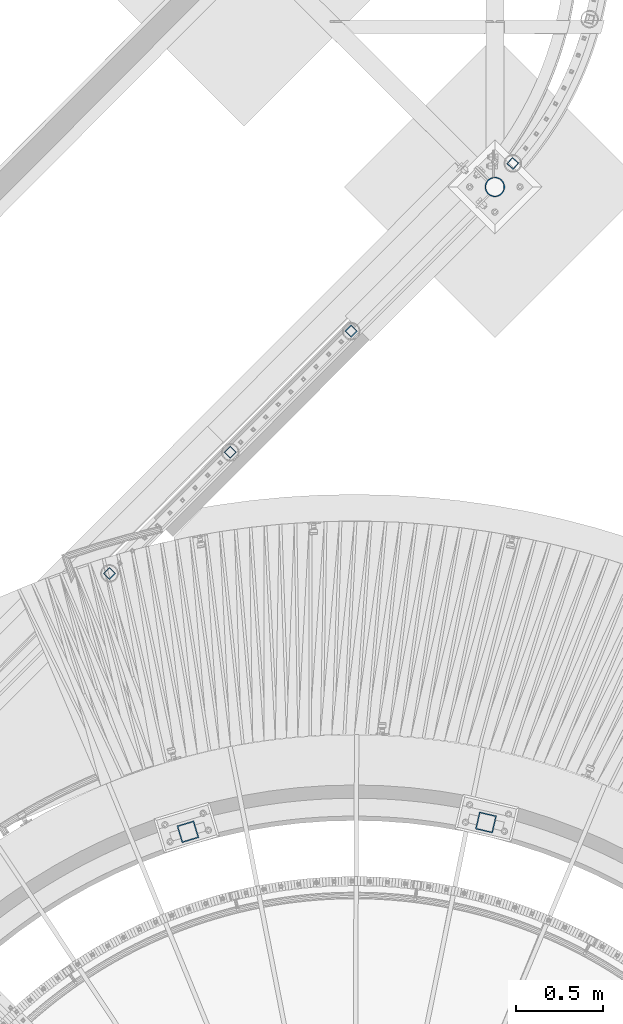
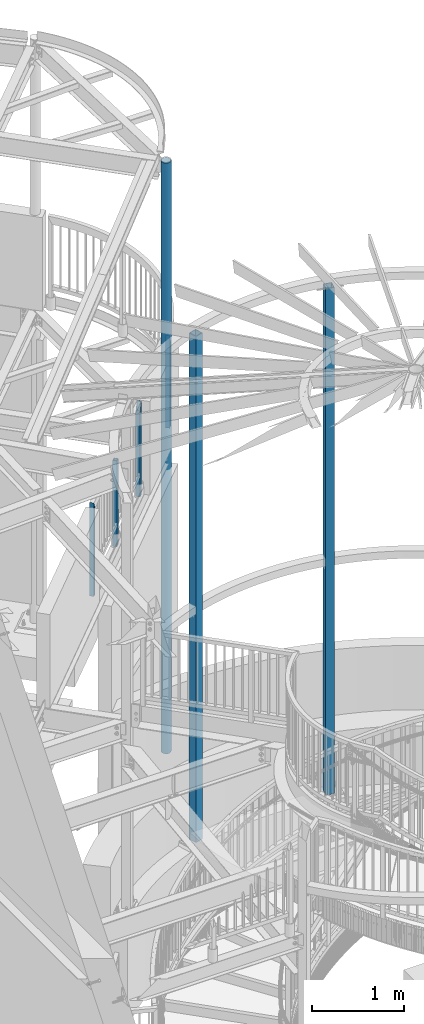
# One storey, part 136 of 975: 7 columns.
"""IFC2X3 building model written with IfcOpenShell, lengths in millimetres."""

from ifc_helpers import new_model, si_unit, frame, origin_with_axes, place, context, subcontext, project, spatial, faceted_brep, material, type_object, element, save


model = new_model("IFC2X3")

# Units and contexts
model_context = context("Model", 3, precision=1e-05, world=origin_with_axes())
body_context = subcontext(model_context, "Body", "Model", "MODEL_VIEW")
ifc_project = project(units=[si_unit("LENGTHUNIT", "METRE", prefix="MILLI"), si_unit("AREAUNIT", "SQUARE_METRE"), si_unit("VOLUMEUNIT", "CUBIC_METRE"), si_unit("MASSUNIT", "GRAM", prefix="KILO"), si_unit("TIMEUNIT", "SECOND"), si_unit("PLANEANGLEUNIT", "RADIAN"), si_unit("SOLIDANGLEUNIT", "STERADIAN"), si_unit("THERMODYNAMICTEMPERATUREUNIT", "DEGREE_CELSIUS"), si_unit("LUMINOUSINTENSITYUNIT", "LUMEN")], contexts=[model_context])

# Site, building, storey
site_placement = place(None, origin_with_axes())
site = spatial("IfcSite", under=ifc_project, at=site_placement, CompositionType="ELEMENT")
building_placement = place(site_placement, origin_with_axes())
building = spatial("IfcBuilding", under=site, at=building_placement, Name="Undefined", CompositionType="ELEMENT")
storey_placement = place(building_placement, origin_with_axes())
storey = spatial("IfcBuildingStorey", under=building, at=storey_placement, Name="Undefined", CompositionType="ELEMENT", Elevation=0.0)

# Columns
ifc_material_1 = material()
column_type_1 = type_object("IfcColumnType", Name="HSS2X2X.188_TUBES", PredefinedType="NOTDEFINED")
column_1_placement = place(storey_placement, frame((35640.1443808804, 10375.5569760185, 3946.52499999334), z_axis=(0.754051277373998, -0.656815553325773, 0.0), x_axis=(0.0, 0.0, 1.0)))
element("IfcColumn", 1, at=column_1_placement, inside=storey, type_object=column_type_1, material=ifc_material_1, Name="HANDRAIL", ObjectType="HSS2X2X.188_TUBES", context=body_context, shape_type="Brep", body=[
    faceted_brep([(0.0, 20.6374999999753, -20.6375000000298), (0.0, -20.6375000000153, -20.6375000000153), (1143.22344323038, -20.6374999999352, -20.6375000000808), (1225.5499881889, 20.6375000000189, -20.6375000000335), (0.0, -20.6374999999825, 20.6375000000335), (1142.9999881907, -20.6375000000262, 20.6375000000335), (0.0, 20.6375000000116, 20.6375000000189), (1225.32653314923, 20.637499999928, 20.6375000000808), (0.0, 25.3999999999724, -25.4000000000342), (0.0, 25.400000000016, 25.4000000000196), (1234.7999666014, 25.3999999999105, 25.400000000107), (1235.07498818869, 25.4000000000233, -25.4000000000415), (0.0, -25.399999999976, 25.4000000000378), (1133.47498818362, -25.3999999995285, 25.4000000000997), (0.0, -25.400000000016, -25.4000000000196), (1133.7500097782, -25.3999999999141, -25.400000000107)], [[[0, 1, 2, 3]], [[1, 4, 5, 2]], [[4, 6, 7, 5]], [[6, 0, 3, 7]], [[8, 9, 10, 11]], [[9, 12, 13, 10]], [[12, 14, 15, 13]], [[14, 8, 11, 15]], [[13, 15, 11, 10], [5, 7, 3, 2]], [[14, 12, 9, 8], [6, 4, 1, 0]]]),
])
column_2_placement = place(storey_placement, frame((34716.2537531138, 9417.0036408675, 3937.00002018607), z_axis=(0.706215711946904, 0.707996728946771, 0.0), x_axis=(0.0, 0.0, 1.0)))
element("IfcColumn", 2, at=column_2_placement, inside=storey, type_object=column_type_1, material=ifc_material_1, Name="HANDRAIL", ObjectType="HSS2X2X.188_TUBES", context=body_context, shape_type="Brep", body=[
    faceted_brep([(0.0, 20.6374999999753, -20.6375000000298), (0.0, -20.6375000000153, -20.6375000000153), (1152.52497983932, -20.6374999999462, -20.6374999999525), (1152.52555129904, 20.6375000000444, -20.6374999999498), (0.0, -20.6374999999825, 20.6375000000335), (1235.07440836204, -20.637500000048, 20.6374999999534), (0.0, 20.6375000000116, 20.6375000000189), (1235.07497982248, 20.6374999999534, 20.6374999999471), (0.0, 25.3999999999724, -25.4000000000342), (0.0, 25.400000000016, 25.4000000000196), (1244.59997982054, 25.399999999936, 25.3999999999351), (1143.00068317638, 25.4000000000487, -25.3999999999396), (0.0, -25.399999999976, 25.4000000000378), (1244.59927648469, -25.400000000056, 25.3999999999469), (0.0, -25.400000000016, -25.4000000000196), (1143.0, -25.4000000000106, -25.4000000000451)], [[[0, 1, 2, 3]], [[1, 4, 5, 2]], [[4, 6, 7, 5]], [[6, 0, 3, 7]], [[8, 9, 10, 11]], [[9, 12, 13, 10]], [[12, 14, 15, 13]], [[14, 8, 11, 15]], [[13, 15, 11, 10], [5, 7, 3, 2]], [[14, 12, 9, 8], [6, 4, 1, 0]]]),
])
column_3_placement = place(storey_placement, frame((34025.6656658427, 8724.63223610959, 3937.00000589273), z_axis=(0.706215711946904, 0.707996728946771, 0.0), x_axis=(5.03999997501794e-07, 5.04999999806568e-07, 0.999999999999746)))
element("IfcColumn", 3, at=column_3_placement, inside=storey, type_object=column_type_1, material=ifc_material_1, Name="HANDRAIL", ObjectType="HSS2X2X.188_TUBES", context=body_context, shape_type="Brep", body=[
    faceted_brep([(0.0, 20.6374999999753, -20.6375000000298), (0.0, -20.6375000000153, -20.6375000000153), (1142.99998821453, -20.6374999999462, -20.6374999999534), (1142.99998821453, 20.6374999999462, -20.6374999999516), (0.0, -20.6374999999825, 20.6375000000335), (1142.9999881907, -20.6375000000262, 20.6375000000335), (0.0, 20.6375000000116, 20.6375000000189), (1142.99998829488, 20.6375000000335, 20.637500000048), (0.0, 25.3999999999724, -25.4000000000342), (0.0, 25.400000000016, 25.4000000000196), (1143.0, 25.4000000000051, 25.4000000000378), (1143.0, 25.4000000000433, -25.4000000000087), (0.0, -25.399999999976, 25.4000000000378), (1143.0, -25.4000000000451, 25.4000000000087), (0.0, -25.400000000016, -25.4000000000196), (1143.0, -25.4000000000106, -25.4000000000451)], [[[0, 1, 2, 3]], [[1, 4, 5, 2]], [[4, 6, 7, 5]], [[6, 0, 3, 7]], [[8, 9, 10, 11]], [[9, 12, 13, 10]], [[12, 14, 15, 13]], [[14, 8, 11, 15]], [[13, 15, 11, 10], [5, 7, 3, 2]], [[14, 12, 9, 8], [6, 4, 1, 0]]]),
])
column_4_placement = place(storey_placement, frame((33335.0272327246, 8032.31295428916, 3937.00001178547), z_axis=(0.706215711946904, 0.707996728946771, 0.0), x_axis=(0.0, 0.0, 1.0)))
element("IfcColumn", 4, at=column_4_placement, inside=storey, type_object=column_type_1, material=ifc_material_1, Name="HANDRAIL", ObjectType="HSS2X2X.188_TUBES", context=body_context, shape_type="Brep", body=[
    faceted_brep([(0.0, 20.6374999999753, -20.6375000000298), (0.0, -20.6375000000153, -20.6375000000153), (1235.074979717, -20.6374999999462, -20.6374999999462), (1235.07441672946, 20.6375000000517, -20.6374999999498), (0.0, -20.6374999999825, 20.6375000000335), (1152.52555966645, -20.6375000000407, 20.6374999999534), (0.0, 20.6375000000116, 20.6375000000189), (1152.52497980387, 20.6374999999534, 20.6374999999534), (0.0, 25.3999999999724, -25.4000000000342), (0.0, 25.400000000016, 25.4000000000196), (1143.0, 25.4000000000051, 25.4000000000378), (1244.59928485212, 25.400000000056, -25.3999999999396), (0.0, -25.399999999976, 25.4000000000378), (1143.0006915438, -25.4000000000451, 25.3999999999469), (0.0, -25.400000000016, -25.4000000000196), (1244.59997970698, -25.399999999936, -25.399999999936)], [[[0, 1, 2, 3]], [[1, 4, 5, 2]], [[4, 6, 7, 5]], [[6, 0, 3, 7]], [[8, 9, 10, 11]], [[9, 12, 13, 10]], [[12, 14, 15, 13]], [[14, 8, 11, 15]], [[13, 15, 11, 10], [5, 7, 3, 2]], [[14, 12, 9, 8], [6, 4, 1, 0]]]),
])
column_type_2 = type_object("IfcColumnType", Name="HSS4X4X1/4", PredefinedType="NOTDEFINED")
for number, where, z_axis, x_axis, name in (
    (5, (35486.8952015768, 6608.95381608165, 1409.7), (0.973539033329667, -0.228520788077446, 0.0), (0.0, 0.0, 1.0), "COLUMN"),
    (6, (33783.4201680663, 6555.71655541384, 1409.7), (0.957369928409554, 0.288864709123642, 0.0), (0.0, 0.0, 1.0), "COLUMN"),
):
    element("IfcColumn", number, at=place(storey_placement, frame(where, z_axis=z_axis, x_axis=x_axis)), inside=storey, type_object=column_type_2, material=ifc_material_1, Name=name, ObjectType="HSS4X4X1/4", context=body_context, shape_type="Brep", body=[
        faceted_brep([(19.0499999999988, 44.4499999999998, -44.4500000000007), (19.0499999999988, -44.4499999999998, -44.4500000000007), (6753.225, -44.4499999999571, -44.4499999999389), (6753.225, 44.4500000000589, -44.4499999999462), (19.0499999999988, -44.4499999999998, 44.4500000000007), (6753.225, -44.4500000000626, 44.4499999999607), (19.0499999999988, 44.4499999999998, 44.4500000000007), (6753.225, 44.4499999999571, 44.4499999999498), (19.0499999999988, 50.8000000000002, -50.7999999999993), (19.0499999999988, 50.8000000000002, 50.7999999999993), (6753.225, 50.7999999999483, 50.7999999999447), (6753.225, 50.8000000000648, -50.7999999999447), (19.0499999999988, -50.8000000000002, 50.7999999999993), (6753.225, -50.800000000072, 50.799999999952), (19.0499999999988, -50.8000000000002, -50.7999999999993), (6753.225, -50.7999999999556, -50.7999999999302)], [[[0, 1, 2, 3]], [[1, 4, 5, 2]], [[4, 6, 7, 5]], [[6, 0, 3, 7]], [[8, 9, 10, 11]], [[9, 12, 13, 10]], [[12, 14, 15, 13]], [[14, 8, 11, 15]], [[13, 15, 11, 10], [5, 7, 3, 2]], [[14, 12, 9, 8], [6, 4, 1, 0]]]),
    ])
ifc_material_2 = material(Name="STEEL/A53")
column_type_3 = type_object("IfcColumnType", Name="PIPE4STD", PredefinedType="NOTDEFINED")
column_5_placement = place(storey_placement, frame((35537.775, 10240.9625, -266.7), z_axis=(-0.707106781186601, 0.707106781186494, 2.36468622460961e-14), x_axis=(0.0, 0.0, 1.0)))
element("IfcColumn", 7, at=column_5_placement, inside=storey, type_object=column_type_3, material=ifc_material_2, Name="COLUMN", ObjectType="PIPE4STD", context=body_context, shape_type="Brep", body=[
    faceted_brep([(19.0500000000025, -51.1301999999996, 0.0), (19.0500000000025, -48.6277098894743, 15.8001007257917), (7877.175, -48.6277098893952, 15.8001007257117), (7877.175, -51.1301999999414, -6.18456397205591e-11), (19.0500000000025, -41.3652007257897, 30.0535775067656), (7877.175, -41.3652007257042, 30.0535775066855), (19.0500000000025, -30.0535775067647, 41.3652007257915), (7877.175, -30.0535775066783, 41.3652007257115), (19.0500000000025, -15.8001007257899, 48.6277098894752), (7877.175, -15.8001007257044, 48.6277098894061), (19.0500000000025, 0.0, 51.1301999999996), (7877.175, 6.91215973347425e-11, 51.130199999945), (19.0500000000025, 15.8001007257899, 48.6277098894752), (7877.175, 15.800100725839, 48.6277098894425), (19.0500000000025, 30.0535775067647, 41.3652007257915), (7877.175, 30.053577506791, 41.3652007257842), (19.0500000000025, 41.3652007257897, 30.0535775067656), (7877.175, 41.3652007257842, 30.053577506791), (19.0500000000025, 48.6277098894743, 15.8001007257917), (7877.175, 48.6277098894388, 15.8001007258426), (19.0500000000025, 51.1301999999996, 0.0), (7877.175, 51.130199999945, 6.91215973347425e-11), (19.0500000000025, 48.6277098894743, -15.8001007257917), (7877.175, 48.6277098893988, -15.8001007257044), (19.0500000000025, 41.3652007257897, -30.0535775067656), (7877.175, 41.3652007257078, -30.0535775066746), (19.0500000000025, 30.0535775067647, -41.3652007257915), (7877.175, 30.0535775066819, -41.3652007257042), (19.0500000000025, 15.8001007257899, -48.6277098894752), (7877.175, 15.800100725708, -48.6277098893952), (19.0500000000025, 0.0, -51.1301999999996), (7877.175, -6.54836185276508e-11, -51.1301999999378), (19.0500000000025, -15.8001007257899, -48.6277098894752), (7877.175, -15.8001007258354, -48.6277098894352), (19.0500000000025, -30.0535775067647, -41.3652007257915), (7877.175, -30.0535775067838, -41.365200725777), (19.0500000000025, -41.3652007257897, -30.0535775067656), (7877.175, -41.365200725777, -30.0535775067838), (19.0500000000025, -48.6277098894743, -15.8001007257917), (7877.175, -48.6277098894352, -15.8001007258317), (19.0500000000025, -57.1499999999996, 0.0), (19.0500000000025, -54.3528799062678, -17.6603212285299), (7877.175, -54.3528799062296, -17.6603212285736), (7877.175, -57.149999999936, -6.54836185276508e-11), (19.0500000000025, -46.2353212285279, -33.5919271685161), (7877.175, -46.2353212285161, -33.5919271685307), (19.0500000000025, -33.5919271685152, -46.235321228527), (7877.175, -33.5919271685343, -46.2353212285161), (19.0500000000025, -17.6603212285281, -54.3528799062697), (7877.175, -17.6603212285736, -54.352879906226), (19.0500000000025, 0.0, -57.1500000000015), (7877.175, -7.27595761418343e-11, -57.149999999936), (19.0500000000025, 17.6603212285281, -54.3528799062697), (7877.175, 17.660321228439, -54.3528799061824), (19.0500000000025, 33.5919271685152, -46.235321228527), (7877.175, 33.5919271684179, -46.2353212284288), (19.0500000000025, 46.2353212285279, -33.5919271685161), (7877.175, 46.2353212284324, -33.5919271684106), (19.0500000000025, 54.3528799062678, -17.6603212285299), (7877.175, 54.352879906186, -17.6603212284317), (19.0500000000025, 57.1499999999996, 0.0), (7877.175, 57.1499999999396, 7.6397554948926e-11), (19.0500000000025, 54.3528799062678, 17.6603212285299), (7877.175, 54.3528799062333, 17.6603212285845), (19.0500000000025, 46.2353212285279, 33.5919271685161), (7877.175, 46.2353212285198, 33.5919271685416), (19.0500000000025, 33.5919271685152, 46.235321228527), (7877.175, 33.5919271685379, 46.2353212285234), (19.0500000000025, 17.6603212285281, 54.3528799062697), (7877.175, 17.6603212285772, 54.3528799062333), (19.0500000000025, 0.0, 57.1500000000015), (7877.175, 7.6397554948926e-11, 57.1499999999432), (19.0500000000025, -17.6603212285281, 54.3528799062697), (7877.175, -17.6603212284354, 54.3528799061896), (19.0500000000025, -33.5919271685152, 46.235321228527), (7877.175, -33.5919271684143, 46.2353212284361), (19.0500000000025, -46.2353212285279, 33.5919271685161), (7877.175, -46.2353212284288, 33.5919271684179), (19.0500000000025, -54.3528799062678, 17.6603212285299), (7877.175, -54.3528799061824, 17.660321228439)], [[[0, 1, 2, 3]], [[1, 4, 5, 2]], [[4, 6, 7, 5]], [[6, 8, 9, 7]], [[8, 10, 11, 9]], [[10, 12, 13, 11]], [[12, 14, 15, 13]], [[14, 16, 17, 15]], [[16, 18, 19, 17]], [[18, 20, 21, 19]], [[20, 22, 23, 21]], [[22, 24, 25, 23]], [[24, 26, 27, 25]], [[26, 28, 29, 27]], [[28, 30, 31, 29]], [[30, 32, 33, 31]], [[32, 34, 35, 33]], [[34, 36, 37, 35]], [[36, 38, 39, 37]], [[38, 0, 3, 39]], [[40, 41, 42, 43]], [[41, 44, 45, 42]], [[44, 46, 47, 45]], [[46, 48, 49, 47]], [[48, 50, 51, 49]], [[50, 52, 53, 51]], [[52, 54, 55, 53]], [[54, 56, 57, 55]], [[56, 58, 59, 57]], [[58, 60, 61, 59]], [[60, 62, 63, 61]], [[62, 64, 65, 63]], [[64, 66, 67, 65]], [[66, 68, 69, 67]], [[68, 70, 71, 69]], [[70, 72, 73, 71]], [[72, 74, 75, 73]], [[74, 76, 77, 75]], [[76, 78, 79, 77]], [[78, 40, 43, 79]], [[45, 47, 49, 51, 53, 55, 57, 59, 61, 63, 65, 67, 69, 71, 73, 75, 77, 79, 43, 42], [5, 7, 9, 11, 13, 15, 17, 19, 21, 23, 25, 27, 29, 31, 33, 35, 37, 39, 3, 2]], [[78, 76, 74, 72, 70, 68, 66, 64, 62, 60, 58, 56, 54, 52, 50, 48, 46, 44, 41, 40], [38, 36, 34, 32, 30, 28, 26, 24, 22, 20, 18, 16, 14, 12, 10, 8, 6, 4, 1, 0]]]),
])

save(model, "model.ifc")
